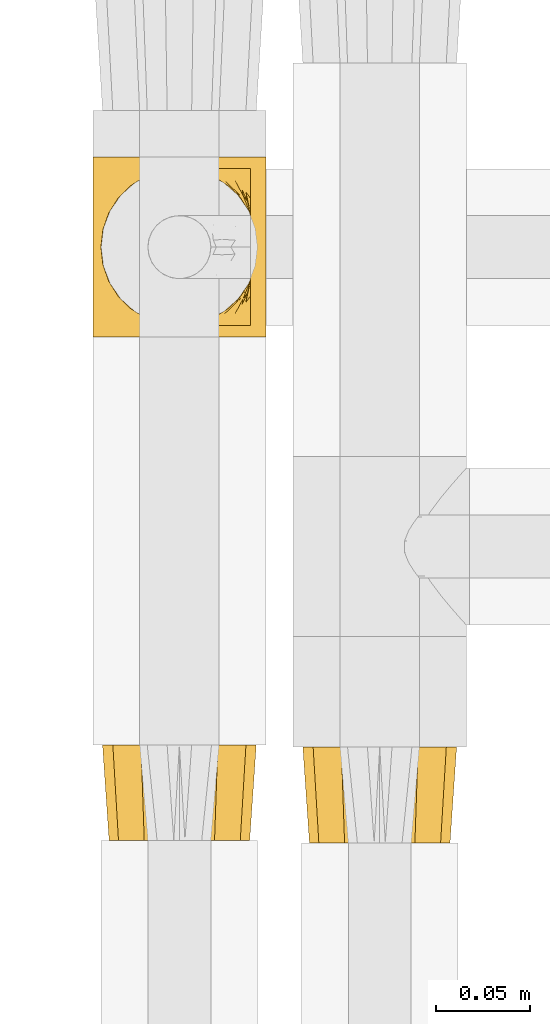
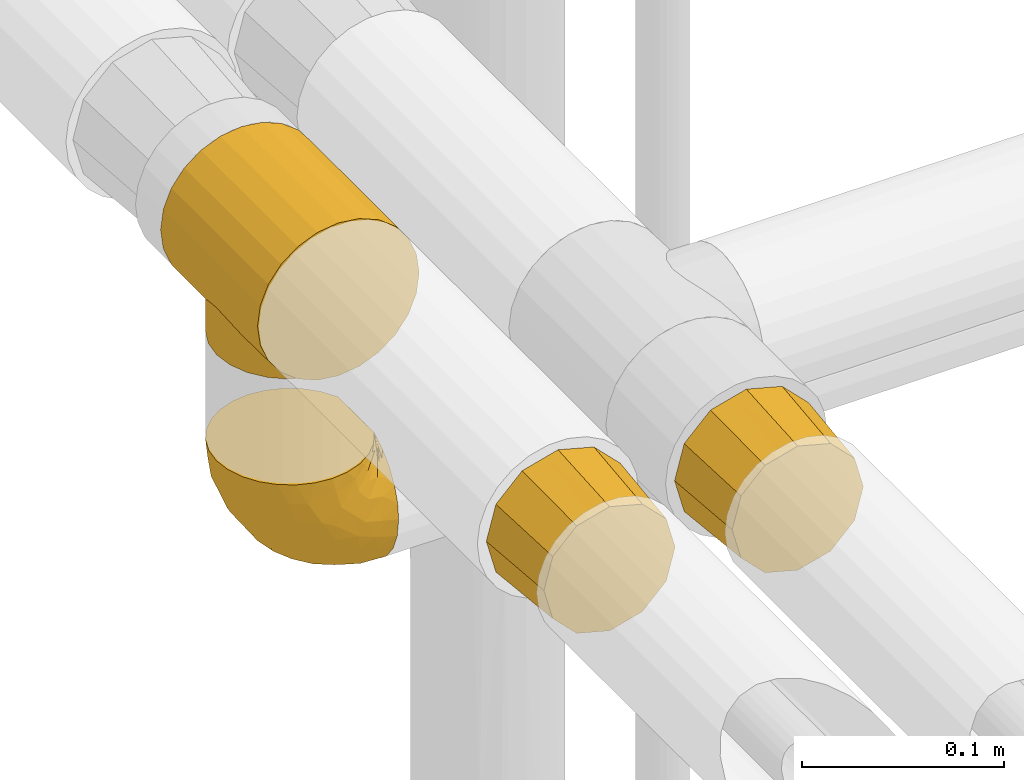
# One storey, part 357 of 827: 4 coverings.
"""IFC2X3 building model written with IfcOpenShell, lengths in millimetres."""

from ifc_helpers import new_model, entity, si_unit, converted_unit, derived_unit, direction, frame, origin, place, context, subcontext, project, spatial, faceted_brep, element, save


model = new_model("IFC2X3")

# Units and contexts
model_context = context("Model", 3, precision=0.01, world=origin(), true_north=direction((6.12303176911189e-17, 1.0)))
body_context = subcontext(model_context, "Body", "Model", "MODEL_VIEW")
ifc_project = project(units=[si_unit("LENGTHUNIT", "METRE", prefix="MILLI"), si_unit("AREAUNIT", "SQUARE_METRE"), si_unit("VOLUMEUNIT", "CUBIC_METRE"), converted_unit("PLANEANGLEUNIT", "DEGREE", entity("IfcRatioMeasure", 0.0174532925199433), si_unit("PLANEANGLEUNIT", "RADIAN"), dimensions=[0, 0, 0, 0, 0, 0, 0]), si_unit("MASSUNIT", "GRAM", prefix="KILO"), derived_unit("MASSDENSITYUNIT", [(si_unit("MASSUNIT", "GRAM", prefix="KILO"), 1), (si_unit("LENGTHUNIT", "METRE"), -3)]), derived_unit("MOMENTOFINERTIAUNIT", [(si_unit("LENGTHUNIT", "METRE"), 4)]), si_unit("TIMEUNIT", "SECOND"), si_unit("FREQUENCYUNIT", "HERTZ"), si_unit("THERMODYNAMICTEMPERATUREUNIT", "DEGREE_CELSIUS"), derived_unit("THERMALTRANSMITTANCEUNIT", [(si_unit("MASSUNIT", "GRAM", prefix="KILO"), 1), (si_unit("THERMODYNAMICTEMPERATUREUNIT", "KELVIN"), -1), (si_unit("TIMEUNIT", "SECOND"), -3)]), derived_unit("VOLUMETRICFLOWRATEUNIT", [(si_unit("LENGTHUNIT", "METRE"), 3), (si_unit("TIMEUNIT", "SECOND"), -1)]), derived_unit("MASSFLOWRATEUNIT", [(si_unit("MASSUNIT", "GRAM", prefix="KILO"), 1), (si_unit("TIMEUNIT", "SECOND"), -1)]), derived_unit("ROTATIONALFREQUENCYUNIT", [(si_unit("TIMEUNIT", "SECOND"), -1)]), si_unit("ELECTRICCURRENTUNIT", "AMPERE"), si_unit("ELECTRICVOLTAGEUNIT", "VOLT"), si_unit("POWERUNIT", "WATT"), si_unit("FORCEUNIT", "NEWTON", prefix="KILO"), si_unit("ILLUMINANCEUNIT", "LUX"), si_unit("LUMINOUSFLUXUNIT", "LUMEN"), si_unit("LUMINOUSINTENSITYUNIT", "CANDELA"), derived_unit("USERDEFINED", [(si_unit("MASSUNIT", "GRAM", prefix="KILO"), -1), (si_unit("LENGTHUNIT", "METRE"), -2), (si_unit("TIMEUNIT", "SECOND"), 3), (si_unit("LUMINOUSFLUXUNIT", "LUMEN"), 1)]), derived_unit("LINEARVELOCITYUNIT", [(si_unit("LENGTHUNIT", "METRE"), 1), (si_unit("TIMEUNIT", "SECOND"), -1)]), si_unit("PRESSUREUNIT", "PASCAL"), derived_unit("USERDEFINED", [(si_unit("LENGTHUNIT", "METRE"), -2), (si_unit("MASSUNIT", "GRAM", prefix="KILO"), 1), (si_unit("TIMEUNIT", "SECOND"), -2)]), derived_unit("LINEARFORCEUNIT", [(si_unit("MASSUNIT", "GRAM", prefix="KILO"), 1), (si_unit("LENGTHUNIT", "METRE"), 1), (si_unit("TIMEUNIT", "SECOND"), -2), (si_unit("LENGTHUNIT", "METRE"), -1)]), derived_unit("PLANARFORCEUNIT", [(si_unit("MASSUNIT", "GRAM", prefix="KILO"), 1), (si_unit("LENGTHUNIT", "METRE"), 1), (si_unit("TIMEUNIT", "SECOND"), -2), (si_unit("LENGTHUNIT", "METRE"), -2)])], contexts=[model_context])

# Site, building, storey
site_placement = place(None, origin())
site = spatial("IfcSite", under=ifc_project, at=site_placement, CompositionType="ELEMENT")
building_placement = place(site_placement, origin())
building = spatial("IfcBuilding", under=site, at=building_placement, CompositionType="ELEMENT")
storey_placement = place(building_placement, frame((0.0, 0.0, 28200.0)))
storey = spatial("IfcBuildingStorey", under=building, at=storey_placement, Name="08", CompositionType="ELEMENT", Elevation=28200.0)

# Coverings
covering_1_placement = place(storey_placement, frame((41321.58, 18182.94, 2952.0)))
element("IfcCovering", 1, at=covering_1_placement, inside=storey, Name=":ADSK_", ObjectType=":ADSK_", PredefinedType="INSULATION", context=body_context, shape_type="Brep", body=[
    faceted_brep([(24.7, 96.0, 88.01), (35.84, 96.0, 92.63), (47.8, 96.0, 94.2), (59.75, 96.0, 92.63), (70.9, 96.0, 88.01), (80.46, 96.0, 80.67), (87.81, 96.0, 71.1), (92.42, 96.0, 59.96), (94.0, 96.0, 48.0), (92.42, 96.0, 36.04), (87.81, 96.0, 24.9), (84.13, 96.0, 20.12), (80.46, 96.0, 15.33), (75.68, 96.0, 11.66), (70.9, 96.0, 7.99), (68.11, 96.0, 6.84), (65.32, 96.0, 5.68), (62.54, 96.0, 4.53), (59.75, 96.0, 3.37), (58.26, 96.0, 3.18), (56.76, 96.0, 2.98), (55.27, 96.0, 2.78), (53.77, 96.0, 2.59), (52.28, 96.0, 2.39), (50.78, 96.0, 2.19), (49.29, 96.0, 2.0), (47.8, 96.0, 1.8), (46.3, 96.0, 2.0), (44.81, 96.0, 2.19), (43.31, 96.0, 2.39), (41.82, 96.0, 2.59), (40.32, 96.0, 2.78), (38.83, 96.0, 2.98), (37.33, 96.0, 3.18), (35.84, 96.0, 3.37), (33.05, 96.0, 4.53), (30.27, 96.0, 5.68), (27.48, 96.0, 6.84), (24.7, 96.0, 7.99), (19.91, 96.0, 11.66), (15.13, 96.0, 15.33), (11.46, 96.0, 20.12), (7.78, 96.0, 24.9), (3.17, 96.0, 36.04), (1.6, 96.0, 48.0), (3.17, 96.0, 59.96), (7.78, 96.0, 71.1), (15.13, 96.0, 80.67), (94.0, 0.0, 48.0), (92.42, 0.0, 59.96), (87.81, 0.0, 71.1), (80.46, 0.0, 80.67), (70.9, 0.0, 88.01), (59.75, 0.0, 92.63), (47.8, 0.0, 94.2), (35.84, 0.0, 92.63), (24.7, 0.0, 88.01), (15.13, 0.0, 80.67), (7.78, 0.0, 71.1), (3.17, 0.0, 59.96), (1.6, 0.0, 48.0), (3.17, 0.0, 36.04), (7.78, 0.0, 24.9), (11.46, 0.0, 20.12), (15.13, 0.0, 15.33), (19.91, 0.0, 11.66), (24.7, 0.0, 7.99), (27.48, 0.0, 6.84), (30.27, 0.0, 5.68), (33.05, 0.0, 4.53), (35.84, 0.0, 3.37), (37.33, 0.0, 3.18), (38.83, 0.0, 2.98), (40.32, 0.0, 2.78), (41.82, 0.0, 2.59), (43.31, 0.0, 2.39), (44.81, 0.0, 2.19), (46.3, 0.0, 2.0), (47.8, 0.0, 1.8), (49.29, 0.0, 2.0), (50.78, 0.0, 2.19), (52.28, 0.0, 2.39), (53.77, 0.0, 2.59), (55.27, 0.0, 2.78), (56.76, 0.0, 2.98), (58.26, 0.0, 3.18), (59.75, 0.0, 3.37), (62.54, 0.0, 4.53), (65.32, 0.0, 5.68), (68.11, 0.0, 6.84), (70.9, 0.0, 7.99), (75.68, 0.0, 11.66), (80.46, 0.0, 15.33), (84.13, 0.0, 20.12), (87.81, 0.0, 24.9), (92.42, 0.0, 36.04), (56.64, 88.77, 2.78), (55.37, 88.92, 2.64), (54.11, 89.08, 2.5), (89.65, 48.0, 28.43), (88.47, 38.15, 26.09), (80.84, 22.31, 15.71), (68.96, 83.88, 7.12), (64.76, 86.02, 5.23), (62.47, 86.89, 4.46), (60.19, 87.75, 3.69), (85.42, 29.67, 21.19), (74.73, 15.97, 10.46), (49.06, 6.3, 1.94), (50.32, 6.46, 2.08), (80.84, 73.69, 15.71), (85.42, 66.33, 21.19), (57.9, 7.39, 2.92), (88.47, 57.85, 26.09), (50.32, 89.54, 2.08), (74.73, 80.03, 10.46), (64.76, 9.98, 5.23), (68.96, 12.12, 7.12), (70.88, 13.4, 8.23), (60.19, 8.25, 3.69), (54.11, 6.92, 2.5), (55.37, 7.08, 2.64), (56.64, 7.23, 2.78), (52.85, 6.77, 2.36), (67.04, 10.84, 6.0), (67.04, 85.16, 6.0), (62.47, 9.11, 4.46), (70.88, 82.6, 8.23), (52.85, 89.23, 2.36), (57.9, 88.61, 2.92), (49.06, 89.7, 1.94), (47.8, 6.15, 1.8), (47.8, 89.85, 1.8), (42.74, 6.77, 2.36), (26.63, 12.12, 7.12), (37.69, 7.39, 2.92), (37.69, 88.61, 2.92), (35.4, 87.75, 3.69), (24.71, 13.4, 8.23), (20.86, 15.97, 10.46), (30.83, 86.02, 5.23), (33.12, 86.89, 4.46), (28.55, 10.84, 6.0), (14.76, 22.31, 15.71), (35.4, 8.25, 3.69), (38.95, 7.23, 2.78), (45.27, 6.46, 2.08), (38.95, 88.77, 2.78), (10.17, 29.67, 21.19), (45.27, 89.54, 2.08), (42.74, 89.23, 2.36), (24.71, 82.6, 8.23), (20.86, 80.03, 10.46), (26.63, 83.88, 7.12), (30.83, 9.98, 5.23), (33.12, 9.11, 4.46), (28.55, 85.16, 6.0), (5.95, 48.0, 28.43), (46.53, 89.7, 1.94), (7.12, 38.15, 26.09), (41.48, 89.08, 2.5), (10.17, 66.33, 21.19), (14.76, 73.69, 15.71), (40.22, 88.92, 2.64), (41.48, 6.92, 2.5), (7.12, 57.85, 26.09), (40.22, 7.08, 2.64), (46.53, 6.3, 1.94), (88.22, 37.17, 0.0), (84.04, 27.07, 0.0), (77.39, 18.41, 0.0), (68.72, 11.76, 0.0), (63.67, 9.67, 0.0), (61.15, 8.62, 0.0), (58.63, 7.58, 0.0), (55.92, 7.22, 0.0), (53.21, 6.86, 0.0), (50.5, 6.51, 0.0), (47.8, 6.15, 0.0), (45.09, 6.51, 0.0), (42.38, 6.86, 0.0), (39.67, 7.22, 0.0), (36.96, 7.58, 0.0), (34.44, 8.62, 0.0), (31.92, 9.67, 0.0), (26.87, 11.76, 0.0), (18.2, 18.41, 0.0), (11.55, 27.07, 0.0), (7.37, 37.17, 0.0), (5.95, 48.0, 0.0), (7.37, 58.83, 0.0), (11.55, 68.92, 0.0), (18.2, 77.59, 0.0), (26.87, 84.24, 0.0), (31.92, 86.33, 0.0), (34.44, 87.38, 0.0), (36.96, 88.42, 0.0), (39.67, 88.78, 0.0), (42.38, 89.14, 0.0), (45.09, 89.49, 0.0), (47.8, 89.85, 0.0), (50.5, 89.49, 0.0), (53.21, 89.14, 0.0), (55.92, 88.78, 0.0), (58.63, 88.42, 0.0), (61.15, 87.38, 0.0), (63.67, 86.33, 0.0), (68.72, 84.24, 0.0), (77.39, 77.59, 0.0), (84.04, 68.92, 0.0), (88.22, 58.83, 0.0), (89.65, 48.0, 0.0)], [[[0, 1, 2, 3, 4, 5, 6, 7, 8, 9, 10, 11, 12, 13, 14, 15, 16, 17, 18, 19, 20, 21, 22, 23, 24, 25, 26, 27, 28, 29, 30, 31, 32, 33, 34, 35, 36, 37, 38, 39, 40, 41, 42, 43, 44, 45, 46, 47]], [[48, 49, 50, 51, 52, 53, 54, 55, 56, 57, 58, 59, 60, 61, 62, 63, 64, 65, 66, 67, 68, 69, 70, 71, 72, 73, 74, 75, 76, 77, 78, 79, 80, 81, 82, 83, 84, 85, 86, 87, 88, 89, 90, 91, 92, 93, 94, 95]], [[52, 51, 5, 4]], [[2, 54, 53, 3]], [[53, 52, 4, 3]], [[6, 50, 49, 7]], [[7, 49, 48, 8]], [[5, 51, 50, 6]], [[8, 48, 95, 9]], [[96, 97, 98, 21]], [[94, 99, 95]], [[100, 99, 94]], [[92, 101, 93]], [[14, 102, 15]], [[17, 103, 104, 105]], [[106, 93, 101]], [[101, 91, 107]], [[94, 106, 100]], [[79, 108, 109]], [[110, 11, 111]], [[9, 95, 99]], [[9, 99, 10]], [[112, 86, 85, 84]], [[113, 111, 10]], [[114, 25, 24, 23]], [[11, 110, 12]], [[111, 11, 10]], [[115, 14, 13]], [[113, 10, 99]], [[106, 94, 93]], [[87, 116, 88]], [[92, 91, 101]], [[90, 117, 118, 107]], [[90, 107, 91]], [[86, 119, 87]], [[120, 121, 122, 83]], [[81, 109, 123]], [[89, 124, 117]], [[117, 90, 89]], [[84, 122, 112]], [[125, 16, 15]], [[116, 124, 88]], [[103, 17, 16]], [[125, 15, 102]], [[119, 126, 116, 87]], [[17, 105, 18]], [[12, 110, 13]], [[14, 115, 127, 102]], [[110, 115, 13]], [[23, 22, 128]], [[19, 18, 129, 20]], [[86, 112, 119]], [[129, 18, 105]], [[22, 98, 128]], [[124, 89, 88]], [[21, 20, 96]], [[16, 125, 103]], [[20, 129, 96]], [[120, 83, 82]], [[21, 98, 22]], [[82, 123, 120]], [[83, 122, 84]], [[130, 26, 25]], [[81, 80, 79, 109]], [[114, 23, 128]], [[123, 82, 81]], [[108, 78, 131]], [[26, 130, 132]], [[78, 108, 79]], [[25, 114, 130]], [[74, 133, 75]], [[66, 134, 67]], [[135, 72, 71, 70]], [[34, 136, 137]], [[138, 134, 66, 139]], [[140, 35, 137, 141]], [[139, 66, 65]], [[142, 67, 134]], [[64, 143, 65]], [[70, 144, 135]], [[73, 72, 145]], [[146, 77, 76, 75]], [[32, 147, 136]], [[143, 63, 148]], [[149, 150, 29]], [[136, 34, 33, 32]], [[151, 152, 38, 153]], [[69, 154, 155, 144]], [[137, 35, 34]], [[152, 39, 38]], [[36, 140, 156]], [[154, 69, 68]], [[35, 140, 36]], [[63, 143, 64]], [[148, 63, 62]], [[153, 38, 37]], [[157, 62, 61]], [[27, 158, 149]], [[62, 159, 148]], [[157, 159, 62]], [[61, 60, 44, 43]], [[160, 31, 30]], [[68, 142, 154]], [[156, 37, 36]], [[161, 41, 162]], [[160, 163, 147, 31]], [[74, 164, 133]], [[40, 162, 41]], [[161, 165, 42]], [[39, 162, 40]], [[157, 43, 42]], [[162, 39, 152]], [[43, 157, 61]], [[157, 42, 165]], [[161, 42, 41]], [[142, 68, 67]], [[139, 65, 143]], [[37, 156, 153]], [[69, 144, 70]], [[30, 150, 160]], [[31, 147, 32]], [[145, 166, 164, 73]], [[72, 135, 145]], [[73, 164, 74]], [[29, 28, 27, 149]], [[167, 78, 77]], [[150, 30, 29]], [[146, 75, 133]], [[158, 26, 132]], [[78, 167, 131]], [[26, 158, 27]], [[77, 146, 167]], [[45, 59, 58, 46]], [[46, 58, 57, 47]], [[60, 59, 45, 44]], [[0, 56, 55, 1]], [[1, 55, 54, 2]], [[47, 57, 56, 0]], [[168, 169, 170, 171, 172, 173, 174, 175, 176, 177, 178, 179, 180, 181, 182, 183, 184, 185, 186, 187, 188, 189, 190, 191, 192, 193, 194, 195, 196, 197, 198, 199, 200, 201, 202, 203, 204, 205, 206, 207, 208, 209, 210, 211]], [[112, 175, 174]], [[177, 123, 109]], [[173, 126, 119]], [[124, 172, 171]], [[109, 178, 177]], [[177, 176, 123]], [[172, 124, 116, 126]], [[171, 107, 118, 117, 124]], [[172, 126, 173]], [[174, 119, 112]], [[171, 170, 107]], [[170, 169, 101]], [[119, 174, 173]], [[169, 168, 106]], [[176, 121, 120, 123]], [[121, 176, 175]], [[100, 168, 211]], [[175, 112, 122, 121]], [[101, 169, 106]], [[100, 106, 168]], [[99, 100, 211]], [[178, 109, 108, 131]], [[170, 101, 107]], [[113, 211, 210]], [[111, 210, 209]], [[200, 132, 130, 114]], [[99, 211, 113]], [[129, 204, 203]], [[113, 210, 111]], [[209, 110, 111]], [[104, 206, 205]], [[209, 208, 110]], [[115, 208, 207]], [[104, 205, 105]], [[204, 105, 205]], [[200, 114, 201]], [[201, 114, 128]], [[202, 128, 98, 97]], [[207, 125, 102, 127, 115]], [[125, 207, 206]], [[203, 97, 96, 129]], [[206, 104, 103, 125]], [[105, 204, 129]], [[128, 202, 201]], [[208, 115, 110]], [[202, 97, 203]], [[136, 197, 196]], [[156, 194, 193]], [[149, 200, 199]], [[199, 198, 150]], [[137, 196, 195]], [[193, 152, 151, 153, 156]], [[194, 141, 195]], [[194, 156, 140, 141]], [[193, 192, 152]], [[163, 198, 197]], [[162, 192, 191]], [[191, 190, 161]], [[199, 150, 149]], [[189, 165, 190]], [[198, 163, 160, 150]], [[162, 191, 161]], [[195, 141, 137]], [[165, 161, 190]], [[157, 165, 189]], [[196, 137, 136]], [[200, 149, 158, 132]], [[192, 162, 152]], [[197, 136, 147, 163]], [[159, 189, 188]], [[148, 188, 187]], [[178, 131, 167, 146]], [[157, 189, 159]], [[135, 182, 181]], [[159, 188, 148]], [[187, 143, 148]], [[155, 184, 183]], [[187, 186, 143]], [[139, 186, 185]], [[155, 183, 144]], [[182, 144, 183]], [[178, 146, 179]], [[179, 146, 133]], [[180, 133, 164, 166]], [[185, 142, 134, 138, 139]], [[142, 185, 184]], [[181, 166, 145, 135]], [[184, 155, 154, 142]], [[144, 182, 135]], [[133, 180, 179]], [[186, 139, 143]], [[180, 166, 181]]]),
])
covering_2_placement = place(storey_placement, frame((41326.78, 17914.53, 2957.4)))
element("IfcCovering", 2, at=covering_2_placement, inside=storey, Name=":ADSK_", ObjectType=":ADSK_", PredefinedType="INSULATION", context=body_context, shape_type="Brep", body=[
    faceted_brep([(22.1, 51.0, 78.1), (35.28, 51.0, 81.64), (42.6, 51.0, 83.6), (49.91, 51.0, 81.64), (63.1, 51.0, 78.1), (70.6, 51.0, 70.6), (78.1, 51.0, 63.1), (81.64, 51.0, 49.91), (83.6, 51.0, 42.6), (81.64, 51.0, 35.28), (78.1, 51.0, 22.1), (70.6, 51.0, 14.59), (63.1, 51.0, 7.09), (49.91, 51.0, 3.55), (42.6, 51.0, 1.6), (35.28, 51.0, 3.55), (22.1, 51.0, 7.09), (14.59, 51.0, 14.59), (7.09, 51.0, 22.1), (3.55, 51.0, 35.28), (1.6, 51.0, 42.6), (3.55, 51.0, 49.91), (7.09, 51.0, 63.1), (14.59, 51.0, 70.6), (5.1, 0.0, 42.6), (7.61, 0.0, 33.22), (10.12, 0.0, 23.85), (16.98, 0.0, 16.98), (23.85, 0.0, 10.12), (33.22, 0.0, 7.61), (42.6, 0.0, 5.1), (51.97, 0.0, 7.61), (61.35, 0.0, 10.12), (68.21, 0.0, 16.98), (75.07, 0.0, 23.85), (77.58, 0.0, 33.22), (80.1, 0.0, 42.6), (77.58, 0.0, 51.97), (75.07, 0.0, 61.35), (68.21, 0.0, 68.21), (61.35, 0.0, 75.07), (51.97, 0.0, 77.58), (42.6, 0.0, 80.1), (33.22, 0.0, 77.58), (23.85, 0.0, 75.07), (16.98, 0.0, 68.21), (10.12, 0.0, 61.35), (7.61, 0.0, 51.97)], [[[0, 1, 2, 3, 4, 5, 6, 7, 8, 9, 10, 11, 12, 13, 14, 15, 16, 17, 18, 19, 20, 21, 22, 23]], [[24, 25, 26, 27, 28, 29, 30, 31, 32, 33, 34, 35, 36, 37, 38, 39, 40, 41, 42, 43, 44, 45, 46, 47]], [[10, 9, 8, 36, 35, 34]], [[11, 10, 34, 33, 32, 12]], [[13, 12, 32, 31, 30, 14]], [[16, 15, 14, 30, 29, 28]], [[17, 16, 28, 27, 26, 18]], [[19, 18, 26, 25, 24, 20]], [[22, 21, 20, 24, 47, 46]], [[23, 22, 46, 45, 44, 0]], [[1, 0, 44, 43, 42, 2]], [[4, 3, 2, 42, 41, 40]], [[5, 4, 40, 39, 38, 6]], [[7, 6, 38, 37, 36, 8]]]),
])
covering_3_placement = place(storey_placement, frame((41433.62, 17913.24, 2957.4)))
element("IfcCovering", 3, at=covering_3_placement, inside=storey, Name=":ADSK_", ObjectType=":ADSK_", PredefinedType="INSULATION", context=body_context, shape_type="Brep", body=[
    faceted_brep([(16.98, 0.0, 68.21), (10.12, 0.0, 61.35), (7.61, 0.0, 51.97), (5.1, 0.0, 42.6), (7.61, 0.0, 33.22), (10.12, 0.0, 23.85), (16.98, 0.0, 16.98), (23.85, 0.0, 10.12), (33.22, 0.0, 7.61), (42.6, 0.0, 5.1), (51.97, 0.0, 7.61), (61.35, 0.0, 10.12), (68.21, 0.0, 16.98), (75.07, 0.0, 23.85), (77.58, 0.0, 33.22), (80.1, 0.0, 42.6), (77.58, 0.0, 51.97), (75.07, 0.0, 61.35), (68.21, 0.0, 68.21), (61.35, 0.0, 75.07), (51.97, 0.0, 77.58), (42.6, 0.0, 80.1), (33.22, 0.0, 77.58), (23.85, 0.0, 75.07), (78.1, 51.0, 63.1), (81.64, 51.0, 49.91), (83.6, 51.0, 42.6), (81.64, 51.0, 35.28), (78.1, 51.0, 22.1), (70.6, 51.0, 14.59), (63.1, 51.0, 7.09), (49.91, 51.0, 3.55), (42.6, 51.0, 1.6), (35.28, 51.0, 3.55), (22.1, 51.0, 7.09), (14.59, 51.0, 14.59), (7.09, 51.0, 22.1), (3.55, 51.0, 35.28), (1.6, 51.0, 42.6), (3.55, 51.0, 49.91), (7.09, 51.0, 63.1), (14.59, 51.0, 70.6), (22.1, 51.0, 78.1), (35.28, 51.0, 81.64), (42.6, 51.0, 83.6), (49.91, 51.0, 81.64), (63.1, 51.0, 78.1), (70.6, 51.0, 70.6)], [[[0, 1, 2, 3, 4, 5, 6, 7, 8, 9, 10, 11, 12, 13, 14, 15, 16, 17, 18, 19, 20, 21, 22, 23]], [[24, 25, 26, 27, 28, 29, 30, 31, 32, 33, 34, 35, 36, 37, 38, 39, 40, 41, 42, 43, 44, 45, 46, 47]], [[34, 33, 32, 9, 8, 7]], [[36, 35, 34, 7, 6, 5]], [[37, 36, 5, 4, 3, 38]], [[28, 27, 26, 15, 14, 13]], [[30, 29, 28, 13, 12, 11]], [[31, 30, 11, 10, 9, 32]], [[46, 45, 44, 21, 20, 19]], [[24, 47, 46, 19, 18, 17]], [[25, 24, 17, 16, 15, 26]], [[40, 39, 38, 3, 2, 1]], [[42, 41, 40, 1, 0, 23]], [[43, 42, 23, 22, 21, 44]]]),
])
covering_4_placement = place(storey_placement, frame((41325.93, 18187.49, 2806.55)))
element("IfcCovering", 4, at=covering_4_placement, inside=storey, Name=":ADSK_", ObjectType=":ADSK_", PredefinedType="INSULATION", context=body_context, shape_type="Brep", body=[
    faceted_brep([(25.28, 81.15, 81.45), (17.35, 76.16, 81.45), (10.72, 69.53, 81.45), (5.74, 61.6, 81.45), (2.64, 52.75, 81.45), (1.6, 43.45, 81.45), (2.65, 34.13, 81.45), (5.74, 25.28, 81.45), (10.73, 17.35, 81.45), (17.36, 10.72, 81.45), (25.29, 5.74, 81.45), (34.14, 2.64, 81.45), (43.45, 1.6, 81.45), (52.82, 2.66, 81.45), (61.71, 5.79, 81.45), (69.67, 10.83, 81.45), (76.31, 17.53, 81.45), (81.27, 25.53, 81.45), (81.27, 26.45, 81.45), (81.27, 27.37, 81.45), (81.27, 28.17, 81.45), (81.27, 29.49, 81.45), (81.27, 30.81, 81.45), (81.27, 32.13, 81.45), (81.27, 33.45, 81.45), (81.27, 34.78, 81.45), (81.27, 36.1, 81.45), (81.27, 37.42, 81.45), (81.27, 38.74, 81.45), (81.27, 40.06, 81.45), (81.27, 41.38, 81.45), (81.27, 42.7, 81.45), (81.27, 44.02, 81.45), (81.27, 45.34, 81.45), (81.27, 46.66, 81.45), (81.27, 47.58, 81.45), (81.27, 48.5, 81.45), (81.27, 49.41, 81.45), (81.27, 50.33, 81.45), (81.27, 51.25, 81.45), (81.27, 52.17, 81.45), (81.27, 53.09, 81.45), (81.27, 54.01, 81.45), (81.27, 54.93, 81.45), (81.27, 55.85, 81.45), (81.27, 56.76, 81.45), (81.27, 57.68, 81.45), (81.27, 58.6, 81.45), (81.27, 59.52, 81.45), (81.27, 60.44, 81.45), (81.27, 61.36, 81.45), (76.3, 69.37, 81.45), (69.66, 76.07, 81.45), (61.69, 81.11, 81.45), (52.8, 84.24, 81.45), (43.45, 85.3, 81.45), (34.13, 84.24, 81.45), (81.45, 17.52, 76.3), (81.45, 10.83, 69.67), (81.45, 5.79, 61.7), (81.45, 2.66, 52.81), (81.45, 1.6, 43.45), (81.45, 3.02, 32.61), (81.45, 7.2, 22.52), (81.45, 13.85, 13.85), (81.45, 22.52, 7.2), (81.45, 32.61, 3.02), (81.45, 43.45, 1.6), (81.45, 54.28, 3.02), (81.45, 64.37, 7.2), (81.45, 73.04, 13.85), (81.45, 79.69, 22.52), (81.45, 83.87, 32.61), (81.45, 85.3, 43.45), (81.45, 84.23, 52.81), (81.45, 81.1, 61.7), (81.45, 76.06, 69.67), (81.45, 69.37, 76.3), (81.45, 61.36, 81.27), (81.45, 60.44, 81.27), (81.45, 59.12, 81.27), (81.45, 58.0, 81.27), (81.45, 56.88, 81.27), (81.45, 55.76, 81.27), (81.45, 54.64, 81.27), (81.45, 53.52, 81.27), (81.45, 52.4, 81.27), (81.45, 51.28, 81.27), (81.45, 50.16, 81.27), (81.45, 49.04, 81.27), (81.45, 47.92, 81.27), (81.45, 46.8, 81.27), (81.45, 45.68, 81.27), (81.45, 44.56, 81.27), (81.45, 43.45, 81.27), (81.45, 42.12, 81.27), (81.45, 40.8, 81.27), (81.45, 39.48, 81.27), (81.45, 38.16, 81.27), (81.45, 36.84, 81.27), (81.45, 35.52, 81.27), (81.45, 34.2, 81.27), (81.45, 32.88, 81.27), (81.45, 31.96, 81.27), (81.45, 31.05, 81.27), (81.45, 30.13, 81.27), (81.45, 29.21, 81.27), (81.45, 28.29, 81.27), (81.45, 27.37, 81.27), (81.45, 26.45, 81.27), (81.45, 25.53, 81.27), (81.33, 54.08, 81.31), (81.32, 55.16, 81.33), (81.33, 36.18, 81.31), (81.32, 35.13, 81.32), (81.33, 44.01, 81.31), (81.32, 45.08, 81.32), (81.32, 61.36, 81.32), (81.32, 59.98, 81.32), (81.32, 46.18, 81.32), (81.32, 26.74, 81.32), (81.32, 47.36, 81.32), (81.32, 29.67, 81.32), (81.34, 28.72, 81.3), (81.32, 39.77, 81.32), (81.31, 52.96, 81.33), (81.33, 51.84, 81.31), (81.31, 40.8, 81.33), (81.32, 41.87, 81.32), (81.33, 42.94, 81.32), (81.32, 27.77, 81.32), (81.33, 48.4, 81.31), (81.32, 37.21, 81.32), (81.33, 33.54, 81.31), (81.32, 32.49, 81.32), (81.32, 30.69, 81.32), (81.32, 50.69, 81.32), (81.31, 49.6, 81.33), (81.32, 56.32, 81.32), (81.33, 57.44, 81.31), (81.31, 58.88, 81.33), (81.32, 25.53, 81.32), (81.3, 61.36, 81.36), (81.29, 61.36, 81.4), (81.29, 25.53, 81.4), (81.3, 25.53, 81.36), (81.4, 61.36, 81.29), (81.36, 61.36, 81.3), (81.36, 25.53, 81.3), (81.4, 25.53, 81.29), (81.3, 31.59, 81.35), (81.33, 38.71, 81.31), (74.06, 3.97, 58.5), (45.99, 1.6, 71.95), (58.35, 3.97, 74.57), (67.76, 8.09, 73.93), (66.18, 8.09, 78.18), (76.46, 16.43, 78.04), (77.33, 15.73, 76.23), (71.95, 1.6, 45.99), (72.25, 10.79, 74.01), (78.91, 13.99, 73.57), (76.42, 8.08, 66.66), (73.52, 14.0, 79.09), (76.9, 12.83, 73.14), (65.25, 3.18, 60.34), (62.45, 1.6, 48.54), (74.31, 1.6, 45.36), (59.38, 3.28, 67.22), (48.54, 1.6, 62.45), (67.72, 6.28, 68.67), (55.49, 1.6, 55.49), (79.73, 19.06, 77.84), (73.23, 8.08, 68.16), (45.36, 1.6, 74.31), (15.81, 32.11, 38.78), (6.4, 29.62, 62.1), (7.67, 43.45, 50.89), (68.46, 2.45, 36.91), (59.33, 2.5, 40.37), (48.7, 9.73, 27.86), (53.94, 17.97, 15.77), (65.02, 10.24, 20.13), (60.77, 4.78, 31.54), (72.07, 4.78, 28.25), (26.25, 8.01, 57.26), (22.29, 8.01, 69.99), (16.0, 13.85, 64.58), (46.93, 2.42, 50.64), (14.19, 21.17, 51.97), (58.46, 35.73, 5.72), (61.51, 27.43, 7.42), (4.64, 43.45, 66.14), (68.93, 17.97, 11.35), (29.62, 35.71, 21.64), (24.85, 29.47, 28.57), (38.55, 3.41, 55.38), (31.27, 3.94, 68.51), (9.35, 21.17, 67.48), (37.15, 7.92, 40.78), (47.07, 4.25, 41.53), (26.49, 11.75, 46.11), (23.01, 18.31, 40.32), (19.4, 24.94, 38.36), (48.06, 28.78, 11.84), (42.46, 35.82, 12.56), (50.89, 43.45, 7.67), (35.78, 28.38, 19.39), (24.98, 43.45, 24.98), (16.33, 43.45, 37.94), (66.14, 43.45, 4.64), (30.96, 21.21, 28.09), (41.83, 16.48, 23.73), (33.28, 13.85, 34.03), (37.94, 43.45, 16.33), (67.39, 82.11, 29.29), (58.47, 51.41, 5.77), (32.5, 57.45, 21.44), (15.79, 54.78, 38.8), (15.99, 73.03, 64.58), (9.34, 65.7, 67.49), (56.91, 76.65, 22.9), (63.5, 68.92, 12.54), (44.08, 68.01, 20.04), (26.24, 78.88, 57.26), (22.27, 78.88, 69.99), (31.26, 82.94, 68.51), (23.95, 64.44, 34.54), (63.79, 84.49, 38.81), (62.45, 85.3, 48.54), (71.95, 85.3, 45.99), (45.36, 85.3, 74.31), (67.83, 57.84, 5.36), (70.28, 76.65, 18.96), (42.11, 51.19, 12.79), (6.39, 57.26, 62.11), (43.54, 78.14, 33.14), (58.03, 82.35, 33.44), (14.18, 65.7, 51.98), (56.34, 84.61, 43.42), (48.09, 84.36, 48.62), (48.54, 85.3, 62.45), (55.49, 85.3, 55.49), (21.78, 73.03, 49.68), (38.54, 83.48, 55.37), (45.99, 85.3, 71.95), (72.79, 84.54, 36.37), (33.26, 73.03, 34.04), (35.53, 79.54, 44.1), (53.66, 59.46, 9.99), (43.03, 73.5, 26.41), (49.68, 82.57, 39.19), (74.06, 82.92, 58.5), (59.37, 83.62, 67.22), (58.34, 82.92, 74.57), (67.75, 78.81, 73.92), (78.91, 72.9, 73.57), (76.9, 74.06, 73.14), (78.08, 78.81, 66.19), (73.23, 78.81, 68.16), (79.73, 67.83, 77.84), (77.34, 71.15, 76.23), (73.51, 72.91, 79.08), (76.45, 70.47, 78.04), (66.41, 78.81, 77.18), (67.7, 80.62, 68.66), (72.24, 76.11, 74.0), (65.25, 83.71, 60.34)], [[[0, 1, 2, 3, 4, 5, 6, 7, 8, 9, 10, 11, 12, 13, 14, 15, 16, 17, 18, 19, 20, 21, 22, 23, 24, 25, 26, 27, 28, 29, 30, 31, 32, 33, 34, 35, 36, 37, 38, 39, 40, 41, 42, 43, 44, 45, 46, 47, 48, 49, 50, 51, 52, 53, 54, 55, 56]], [[57, 58, 59, 60, 61, 62, 63, 64, 65, 66, 67, 68, 69, 70, 71, 72, 73, 74, 75, 76, 77, 78, 79, 80, 81, 82, 83, 84, 85, 86, 87, 88, 89, 90, 91, 92, 93, 94, 95, 96, 97, 98, 99, 100, 101, 102, 103, 104, 105, 106, 107, 108, 109, 110]], [[111, 84, 112]], [[113, 26, 114]], [[114, 101, 100]], [[115, 93, 116]], [[79, 117, 118]], [[33, 116, 119]], [[117, 49, 118]], [[19, 18, 120]], [[119, 121, 34]], [[122, 21, 123]], [[97, 96, 124]], [[86, 125, 126]], [[116, 92, 119]], [[127, 96, 128]], [[32, 129, 115]], [[19, 120, 130]], [[121, 90, 131]], [[94, 115, 129]], [[115, 116, 32]], [[118, 49, 48]], [[113, 99, 132]], [[133, 114, 25]], [[24, 134, 133]], [[135, 22, 122]], [[136, 137, 88]], [[84, 83, 112]], [[138, 82, 139]], [[130, 20, 19]], [[118, 48, 140]], [[81, 140, 139]], [[123, 21, 20]], [[141, 120, 18]], [[139, 82, 81]], [[130, 107, 123]], [[49, 117, 142, 143, 50]], [[18, 17, 144, 145, 141]], [[79, 78, 146, 147, 117]], [[109, 141, 148, 149, 110]], [[102, 133, 134]], [[105, 135, 122]], [[118, 80, 79]], [[80, 118, 140]], [[120, 109, 108]], [[47, 46, 140, 48]], [[81, 80, 140]], [[44, 112, 138]], [[93, 115, 94]], [[46, 139, 140]], [[46, 45, 139]], [[139, 45, 138]], [[138, 112, 83]], [[85, 84, 111]], [[112, 43, 111]], [[83, 82, 138]], [[106, 122, 123]], [[105, 122, 106]], [[21, 122, 22]], [[124, 29, 28]], [[33, 32, 116]], [[128, 129, 31]], [[32, 31, 129]], [[34, 33, 119]], [[116, 93, 92]], [[129, 95, 94]], [[95, 129, 128]], [[41, 40, 125, 42]], [[119, 91, 121]], [[36, 35, 131, 37]], [[137, 131, 89]], [[121, 131, 35]], [[90, 121, 91]], [[119, 92, 91]], [[136, 126, 39]], [[125, 86, 85]], [[42, 125, 111]], [[85, 111, 125]], [[150, 23, 22]], [[130, 108, 107]], [[130, 123, 20]], [[107, 106, 123]], [[137, 37, 131]], [[136, 38, 137]], [[89, 88, 137]], [[131, 90, 89]], [[124, 151, 97]], [[40, 39, 126]], [[87, 126, 136]], [[86, 126, 87]], [[136, 88, 87]], [[40, 126, 125]], [[39, 38, 136]], [[95, 128, 96]], [[30, 128, 31]], [[29, 124, 127]], [[127, 128, 30]], [[151, 124, 28]], [[127, 30, 29]], [[127, 124, 96]], [[151, 98, 97]], [[45, 44, 138]], [[26, 113, 132]], [[113, 100, 99]], [[132, 151, 27]], [[27, 26, 132]], [[26, 25, 114]], [[100, 113, 114]], [[101, 133, 102]], [[133, 101, 114]], [[28, 27, 151]], [[132, 99, 98]], [[23, 134, 24]], [[25, 24, 133]], [[134, 23, 150]], [[135, 104, 150]], [[150, 104, 103]], [[103, 102, 134]], [[130, 120, 108]], [[109, 120, 141]], [[42, 111, 43]], [[112, 44, 43]], [[104, 135, 105]], [[134, 150, 103]], [[135, 150, 22]], [[35, 34, 121]], [[137, 38, 37]], [[98, 151, 132]], [[59, 152, 60]], [[13, 153, 154]], [[155, 156, 154]], [[157, 158, 141]], [[159, 60, 152]], [[160, 157, 155]], [[161, 162, 58]], [[58, 162, 59]], [[144, 16, 163]], [[58, 57, 161]], [[162, 161, 164]], [[157, 163, 155]], [[163, 16, 15]], [[57, 149, 161]], [[152, 165, 166]], [[157, 144, 163]], [[60, 159, 167, 61]], [[156, 14, 154]], [[163, 156, 155]], [[155, 154, 168]], [[168, 154, 169]], [[155, 170, 160]], [[57, 110, 149]], [[144, 17, 16]], [[156, 15, 14]], [[171, 165, 168]], [[158, 164, 172]], [[14, 13, 154]], [[157, 141, 145, 144]], [[173, 164, 158]], [[173, 160, 170]], [[171, 166, 165]], [[168, 165, 170]], [[168, 169, 171]], [[152, 173, 165]], [[170, 155, 168]], [[165, 173, 170]], [[160, 173, 158]], [[172, 149, 148]], [[148, 141, 158]], [[158, 157, 160]], [[152, 166, 159]], [[173, 152, 162]], [[59, 162, 152]], [[13, 12, 174, 153]], [[153, 169, 154]], [[15, 156, 163]], [[162, 164, 173]], [[172, 164, 161]], [[149, 172, 161]], [[158, 172, 148]], [[175, 176, 177]], [[178, 166, 179]], [[180, 181, 182]], [[183, 184, 178]], [[185, 186, 187]], [[171, 188, 179]], [[174, 12, 11]], [[189, 176, 175]], [[190, 66, 191]], [[176, 6, 192]], [[193, 65, 64]], [[63, 184, 182]], [[63, 182, 64]], [[65, 193, 191]], [[184, 63, 62]], [[175, 194, 195]], [[196, 169, 197]], [[174, 11, 197]], [[8, 7, 198]], [[187, 9, 8]], [[197, 169, 153, 174]], [[197, 11, 10]], [[186, 197, 10]], [[199, 180, 200]], [[197, 185, 196]], [[201, 189, 202]], [[201, 187, 189]], [[195, 203, 175]], [[191, 204, 190]], [[176, 7, 6]], [[177, 176, 192]], [[189, 198, 176]], [[65, 191, 66]], [[198, 187, 8]], [[205, 206, 190]], [[9, 186, 10]], [[181, 207, 204]], [[208, 175, 177, 209]], [[66, 190, 210]], [[211, 212, 213]], [[190, 204, 205]], [[180, 182, 183]], [[193, 182, 181]], [[62, 61, 167]], [[196, 185, 199]], [[196, 200, 188]], [[6, 5, 192]], [[176, 198, 7]], [[187, 198, 189]], [[187, 186, 9]], [[197, 186, 185]], [[200, 180, 183]], [[180, 213, 212]], [[179, 183, 178]], [[185, 201, 199]], [[210, 190, 206]], [[210, 67, 66]], [[205, 204, 207]], [[194, 205, 207]], [[194, 214, 205]], [[195, 194, 207]], [[208, 194, 175]], [[207, 211, 195]], [[202, 203, 211]], [[212, 207, 181]], [[202, 211, 213]], [[201, 202, 213]], [[189, 175, 203]], [[199, 201, 213]], [[187, 201, 185]], [[180, 199, 213]], [[196, 199, 200]], [[211, 203, 195]], [[189, 203, 202]], [[207, 212, 211]], [[180, 212, 181]], [[214, 194, 208]], [[214, 206, 205]], [[196, 188, 169]], [[181, 204, 191]], [[182, 193, 64]], [[191, 193, 181]], [[178, 62, 167]], [[182, 184, 183]], [[62, 178, 184]], [[178, 167, 159, 166]], [[171, 179, 166]], [[200, 183, 179]], [[179, 188, 200]], [[169, 188, 171]], [[71, 215, 72]], [[206, 216, 210]], [[217, 208, 218]], [[216, 68, 210]], [[219, 220, 2]], [[221, 222, 223]], [[224, 225, 226]], [[227, 223, 217]], [[228, 229, 230]], [[56, 231, 226]], [[232, 222, 69]], [[56, 55, 231]], [[70, 233, 71]], [[71, 233, 215]], [[0, 56, 226]], [[208, 217, 234]], [[218, 177, 235]], [[221, 236, 237]], [[238, 220, 219]], [[1, 219, 2]], [[68, 216, 232]], [[235, 3, 220]], [[235, 192, 4]], [[1, 0, 225]], [[228, 239, 229]], [[240, 241, 242]], [[243, 238, 219]], [[224, 226, 244]], [[226, 241, 244]], [[3, 235, 4]], [[69, 222, 70]], [[225, 219, 1]], [[218, 235, 238]], [[243, 219, 224]], [[218, 227, 217]], [[3, 2, 220]], [[218, 208, 209, 177]], [[226, 231, 245, 241]], [[215, 228, 246]], [[247, 248, 236]], [[248, 224, 244]], [[223, 222, 249]], [[233, 222, 221]], [[242, 239, 240]], [[248, 247, 243]], [[217, 223, 249]], [[250, 247, 236]], [[216, 234, 249]], [[218, 238, 227]], [[192, 235, 177]], [[192, 5, 4]], [[72, 246, 73]], [[235, 220, 238]], [[226, 225, 0]], [[219, 225, 224]], [[240, 248, 244]], [[239, 242, 229]], [[236, 248, 251]], [[68, 67, 210]], [[234, 216, 206]], [[216, 249, 232]], [[234, 206, 214, 208]], [[249, 234, 217]], [[222, 232, 249]], [[69, 68, 232]], [[246, 228, 230]], [[237, 228, 215]], [[243, 227, 238]], [[223, 227, 247]], [[73, 246, 230]], [[215, 246, 72]], [[248, 243, 224]], [[227, 243, 247]], [[237, 236, 251]], [[250, 221, 223]], [[222, 233, 70]], [[215, 233, 221]], [[221, 237, 215]], [[239, 237, 251]], [[237, 239, 228]], [[239, 251, 240]], [[248, 240, 251]], [[241, 240, 244]], [[221, 250, 236]], [[223, 247, 250]], [[74, 230, 252]], [[253, 254, 255]], [[146, 77, 256]], [[257, 258, 259]], [[260, 256, 257]], [[260, 261, 147]], [[75, 74, 252]], [[51, 143, 262]], [[263, 143, 142, 117]], [[256, 77, 76]], [[252, 258, 75]], [[253, 241, 254]], [[254, 245, 54]], [[258, 256, 76]], [[53, 52, 264]], [[255, 265, 253]], [[254, 264, 255]], [[255, 264, 262]], [[75, 258, 76]], [[265, 255, 266]], [[255, 262, 263]], [[51, 50, 143]], [[54, 245, 231, 55]], [[51, 262, 52]], [[253, 267, 242]], [[254, 54, 53]], [[266, 259, 265]], [[146, 78, 77]], [[263, 117, 261]], [[146, 256, 260]], [[257, 259, 261]], [[267, 253, 265]], [[229, 267, 252]], [[242, 267, 229]], [[242, 241, 253]], [[252, 267, 259]], [[255, 263, 266]], [[259, 267, 265]], [[261, 117, 147]], [[263, 261, 266]], [[259, 266, 261]], [[230, 74, 73]], [[230, 229, 252]], [[259, 258, 252]], [[254, 241, 245]], [[53, 264, 254]], [[52, 262, 264]], [[143, 263, 262]], [[258, 257, 256]], [[261, 260, 257]], [[146, 260, 147]]]),
])

save(model, "model.ifc")
